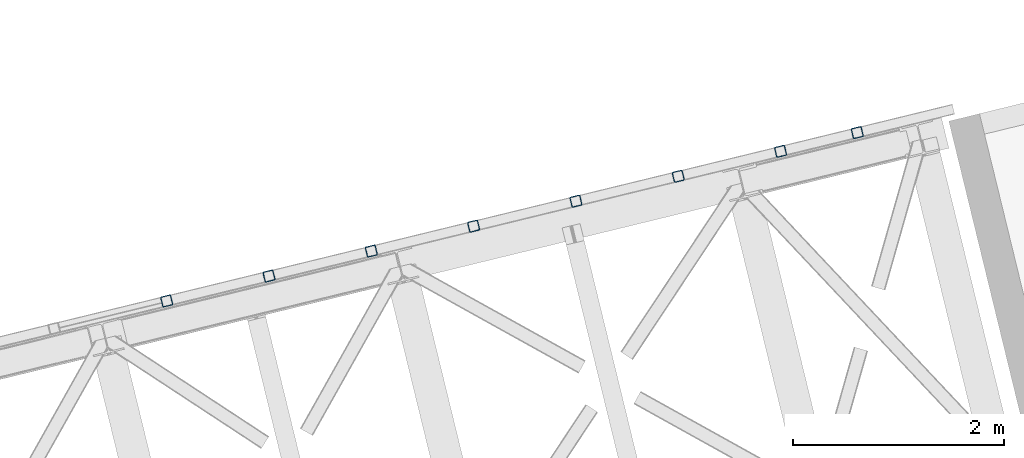
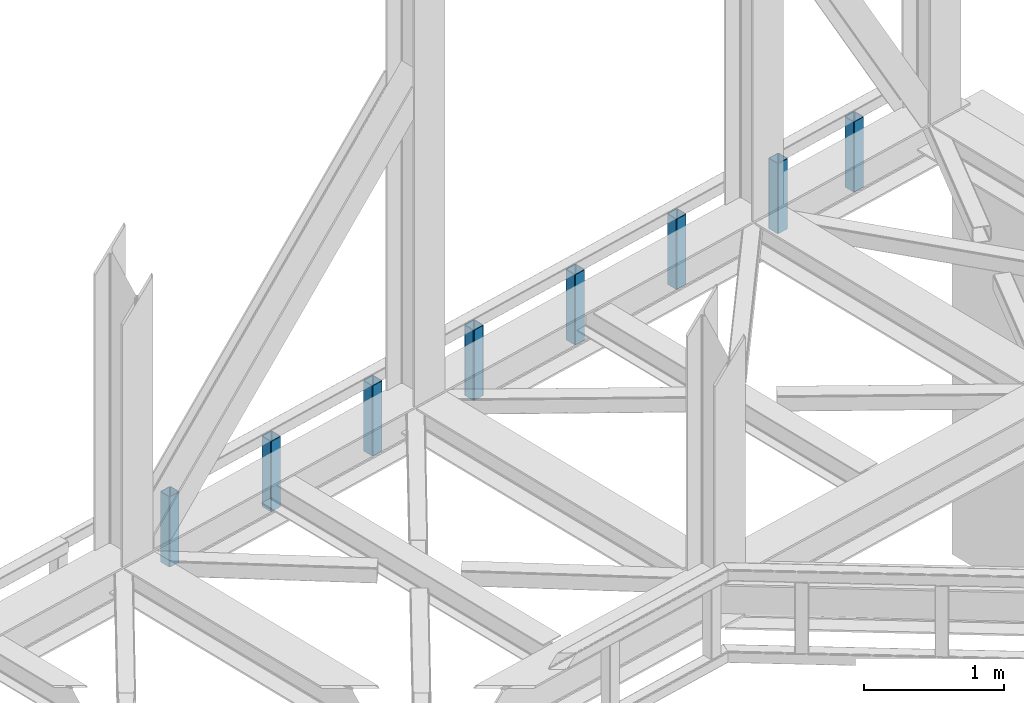
# One storey, part 14 of 92: 8 columns.
"""IFC4 building model written with IfcOpenShell, lengths in millimetres."""

from ifc_helpers import new_model, entity, si_unit, converted_unit, derived_unit, direction, frame, origin, place, context, subcontext, project, spatial, indexed_curve, outline, extrude, type_object, element, save


model = new_model("IFC4")

# Units and contexts
model_context = context("Model", 3, precision=0.01, world=origin(), true_north=direction((6.12303176911189e-17, 1.0)))
plan_context = context("Plan", 3, precision=0.01, world=origin(), true_north=direction((6.12303176911189e-17, 1.0)))
body_context = subcontext(model_context, "Body", "Model", "MODEL_VIEW")
ifc_project = project(units=[si_unit("LENGTHUNIT", "METRE", prefix="MILLI"), si_unit("AREAUNIT", "SQUARE_METRE"), si_unit("VOLUMEUNIT", "CUBIC_METRE"), converted_unit("PLANEANGLEUNIT", "DEGREE", entity("IfcRatioMeasure", 0.0174532925199433), si_unit("PLANEANGLEUNIT", "RADIAN"), dimensions=[0, 0, 0, 0, 0, 0, 0]), si_unit("MASSUNIT", "GRAM", prefix="KILO"), derived_unit("MASSDENSITYUNIT", [(si_unit("MASSUNIT", "GRAM", prefix="KILO"), 1), (si_unit("LENGTHUNIT", "METRE"), -3)]), derived_unit("MOMENTOFINERTIAUNIT", [(si_unit("LENGTHUNIT", "METRE"), 4)]), si_unit("TIMEUNIT", "SECOND"), si_unit("FREQUENCYUNIT", "HERTZ"), si_unit("THERMODYNAMICTEMPERATUREUNIT", "DEGREE_CELSIUS"), derived_unit("THERMALTRANSMITTANCEUNIT", [(si_unit("MASSUNIT", "GRAM", prefix="KILO"), 1), (si_unit("THERMODYNAMICTEMPERATUREUNIT", "KELVIN"), -1), (si_unit("TIMEUNIT", "SECOND"), -3)]), derived_unit("VOLUMETRICFLOWRATEUNIT", [(si_unit("LENGTHUNIT", "METRE"), 3), (si_unit("TIMEUNIT", "SECOND"), -1)]), derived_unit("MASSFLOWRATEUNIT", [(si_unit("MASSUNIT", "GRAM", prefix="KILO"), 1), (si_unit("TIMEUNIT", "SECOND"), -1)]), derived_unit("ROTATIONALFREQUENCYUNIT", [(si_unit("TIMEUNIT", "SECOND"), -1)]), si_unit("ELECTRICCURRENTUNIT", "AMPERE"), si_unit("ELECTRICVOLTAGEUNIT", "VOLT"), si_unit("POWERUNIT", "WATT"), si_unit("FORCEUNIT", "NEWTON", prefix="KILO"), si_unit("ILLUMINANCEUNIT", "LUX"), si_unit("LUMINOUSFLUXUNIT", "LUMEN"), si_unit("LUMINOUSINTENSITYUNIT", "CANDELA"), derived_unit("USERDEFINED", [(si_unit("MASSUNIT", "GRAM", prefix="KILO"), -1), (si_unit("LENGTHUNIT", "METRE"), -2), (si_unit("TIMEUNIT", "SECOND"), 3), (si_unit("LUMINOUSFLUXUNIT", "LUMEN"), 1)]), derived_unit("LINEARVELOCITYUNIT", [(si_unit("LENGTHUNIT", "METRE"), 1), (si_unit("TIMEUNIT", "SECOND"), -1)]), si_unit("PRESSUREUNIT", "PASCAL"), derived_unit("USERDEFINED", [(si_unit("LENGTHUNIT", "METRE"), -2), (si_unit("MASSUNIT", "GRAM", prefix="KILO"), 1), (si_unit("TIMEUNIT", "SECOND"), -2)]), derived_unit("LINEARFORCEUNIT", [(si_unit("MASSUNIT", "GRAM", prefix="KILO"), 1), (si_unit("LENGTHUNIT", "METRE"), 1), (si_unit("TIMEUNIT", "SECOND"), -2), (si_unit("LENGTHUNIT", "METRE"), -1)]), derived_unit("PLANARFORCEUNIT", [(si_unit("MASSUNIT", "GRAM", prefix="KILO"), 1), (si_unit("LENGTHUNIT", "METRE"), 1), (si_unit("TIMEUNIT", "SECOND"), -2), (si_unit("LENGTHUNIT", "METRE"), -2)])], contexts=[model_context, plan_context])

# Site, building, storey
site_placement = place(None, origin())
site = spatial("IfcSite", under=ifc_project, at=site_placement, CompositionType="ELEMENT")
building_placement = place(site_placement, origin())
building = spatial("IfcBuilding", under=site, at=building_placement, CompositionType="ELEMENT")
storey_placement = place(building_placement, frame((0.0, 0.0, 15900.0)))
storey = spatial("IfcBuildingStorey", under=building, at=storey_placement, Name="05", CompositionType="ELEMENT", Elevation=15900.0)

# Columns
column_type_1 = type_object("IfcColumnType", PredefinedType="COLUMN")
placement = place(storey_placement, origin())
element("IfcColumn", 1, at=placement, inside=storey, type_object=column_type_1, ObjectType="Steel Column", PredefinedType="COLUMN", context=body_context, shape_type="SweptSolid", body=[
    extrude(outline(indexed_curve([(29.476895115349, -56.8428769007929), (33.37870155567, -56.8428769007929), (36.9835006657009, -55.3497202197826), (39.7424944585237, -52.5907264269531), (41.2356511395288, -48.9859273169178), (56.8428769007947, 29.4768951153464), (56.8428769007946, 33.3787015556698), (55.3497202197922, 36.9835006657036), (52.5907264269645, 39.7424944585291), (48.9859273169309, 41.2356511395364), (-29.4768951153304, 56.8428769008034), (-33.3787015556703, 56.8428769008026), (-36.983500665692, 55.3497202197928), (-39.742494458524, 52.5907264269628), (-41.2356511395382, 48.985927316927), (-56.8428769008028, -29.4768951153331), (-56.8428769007949, -33.3787015556601), (-55.3497202197833, -36.9835006656934), (-52.5907264269653, -39.7424944585192), (-48.9859273169146, -41.2356511395297), (29.476895115349, -56.8428769007929)], self_intersect=False), holes=[indexed_curve([(-43.1065493048278, -37.3071763475883), (-46.7113484148565, -35.8140196665833), (-49.4703422076867, -33.0550258737518), (-50.963498888688, -29.4502267637233), (-50.9634988886983, -25.5484203234), (-37.3071763475896, 43.1065493048314), (-35.8140196665759, 46.7113484148674), (-33.0550258737591, 49.4703422076902), (-29.4502267637216, 50.9634988887021), (-25.5484203234027, 50.9634988887079), (43.1065493048406, 37.3071763475967), (46.7113484148732, 35.8140196665899), (49.4703422077042, 33.0550258737675), (50.9634988887097, 29.4502267637276), (50.9634988887155, 25.5484203234063), (37.3071763476012, -43.1065493048272), (35.8140196665999, -46.7113484148594), (33.055025873766, -49.4703422076933), (29.4502267637393, -50.963498888696), (25.5484203234126, -50.9634988886982), (-43.1065493048278, -37.3071763475883)], self_intersect=False)]), frame((-2530.87, 20381.28, 3168.0), z_axis=(0.0, 0.0, 1.0), x_axis=(0.906681479027445, 0.4218159498983, 0.0)), (0.0, 0.0, 1.0), 612.000000000008),
])
column_type_2 = type_object("IfcColumnType", PredefinedType="COLUMN")
element("IfcColumn", 2, at=placement, inside=storey, type_object=column_type_2, ObjectType="Steel Column", PredefinedType="COLUMN", context=body_context, shape_type="SweptSolid", body=[
    extrude(outline(indexed_curve([(29.476895115345, -56.8428769007958), (33.378701555666, -56.8428769007958), (36.9835006656971, -55.3497202197856), (39.7424944585291, -52.5907264269556), (41.2356511395342, -48.9859273169203), (56.8428769007987, 29.4768951153397), (56.8428769007984, 33.3787015556633), (55.3497202197884, 36.9835006657005), (52.590726426961, 39.742494458526), (48.9859273169274, 41.2356511395333), (-29.4768951153439, 56.8428769008001), (-33.3787015556647, 56.8428769008), (-36.9835006657036, 55.3497202197934), (-39.7424944585184, 52.5907264269601), (-41.2356511395328, 48.9859273169245), (-56.8428769007992, -29.4768951153395), (-56.8428769007892, -33.3787015556628), (-55.3497202197947, -36.9835006656929), (-52.5907264269596, -39.7424944585218), (-48.9859273169261, -41.2356511395291), (29.476895115345, -56.8428769007958)], self_intersect=False), holes=[indexed_curve([(-43.1065493048226, -37.3071763475907), (-46.7113484148589, -35.8140196665822), (-49.4703422076883, -33.0550258737558), (-50.9634988886878, -29.4502267637235), (-50.9634988886929, -25.5484203234025), (-37.3071763475806, 43.1065493048272), (-35.814019666583, 46.7113484148611), (-33.0550258737619, 49.470342207701), (-29.4502267637245, 50.9634988887035), (-25.548420323398, 50.9634988887057), (43.1065493048361, 37.307176347594), (46.711348414869, 35.8140196665871), (49.4703422076887, 33.0550258737604), (50.9634988887073, 29.4502267637335), (50.9634988887034, 25.5484203234071), (37.3071763475911, -43.1065493048225), (35.8140196665901, -46.7113484148644), (33.0550258737647, -49.4703422076879), (29.450226763735, -50.9634988886988), (25.5484203234099, -50.9634988886969), (-43.1065493048226, -37.3071763475907)], self_intersect=False)]), frame((-1802.21, 20558.9, 3168.0), z_axis=(0.0, 0.0, 1.0), x_axis=(0.906681479027445, 0.4218159498983, 0.0)), (0.0, 0.0, 1.0), 612.000000000008),
])
column_type_3 = type_object("IfcColumnType", PredefinedType="COLUMN")
element("IfcColumn", 3, at=placement, inside=storey, type_object=column_type_3, ObjectType="Steel Column", PredefinedType="COLUMN", context=body_context, shape_type="SweptSolid", body=[
    extrude(outline(indexed_curve([(29.4768951153362, -56.8428769008013), (33.3787015556572, -56.8428769008013), (36.9835006656959, -55.3497202197946), (39.7424944585279, -52.5907264269646), (41.2356511395251, -48.9859273169257), (56.8428769007897, 29.4768951153344), (56.8428769007988, 33.3787015556583), (55.3497202197867, 36.9835006656918), (52.5907264269517, 39.7424944585208), (48.9859273169181, 41.235651139528), (-29.4768951153359, 56.8428769007916), (-33.3787015556661, 56.8428769007911), (-36.9835006656956, 55.3497202197849), (-39.7424944585369, 52.5907264269544), (-41.2356511395322, 48.9859273169194), (-56.8428769007986, -29.4768951153446), (-56.8428769008077, -33.3787015556685), (-55.3497202197869, -36.9835006657012), (-52.5907264269611, -39.7424944585307), (-48.9859273169183, -41.2356511395375), (29.4768951153362, -56.8428769008013)], self_intersect=False), holes=[indexed_curve([(-43.1065493048338, -37.3071763475999), (-46.7113484148666, -35.8140196665834), (-49.4703422076999, -33.0550258737647), (-50.9634988887023, -29.450226763731), (-50.9634988887121, -25.5484203234079), (-37.3071763476053, 43.1065493048196), (-35.8140196665908, 46.7113484148456), (-33.0550258737653, 49.4703422076834), (-29.4502267637372, 50.9634988886903), (-25.5484203234091, 50.9634988886966), (43.106549304825, 37.3071763475849), (46.7113484148594, 35.814019666582), (49.4703422076904, 33.0550258737596), (50.9634988887041, 29.4502267637206), (50.9634988887017, 25.5484203233984), (37.3071763475891, -43.1065493048312), (35.8140196665818, -46.7113484148701), (33.055025873744, -49.4703422077022), (29.4502267637237, -50.9634988887079), (25.5484203234066, -50.9634988887097), (-43.1065493048338, -37.3071763475999)], self_intersect=False)]), frame((-3502.43, 20144.45, 3168.0), z_axis=(0.0, 0.0, 1.0), x_axis=(0.906681479027445, 0.4218159498983, 0.0)), (0.0, 0.0, 1.0), 612.000000000008),
])
column_type_4 = type_object("IfcColumnType", PredefinedType="COLUMN")
element("IfcColumn", 4, at=placement, inside=storey, type_object=column_type_4, ObjectType="Steel Column", PredefinedType="COLUMN", context=body_context, shape_type="SweptSolid", body=[
    extrude(outline(indexed_curve([(29.4768951152886, -56.8428769008306), (33.3787015556115, -56.8428769008306), (36.9835006656346, -55.3497202198244), (39.7424944584773, -52.5907264270008), (41.235651139486, -48.9859273169671), (56.8428769008309, 29.4768951152814), (56.8428769008347, 33.3787015556048), (55.3497202198189, 36.9835006656432), (52.5907264270037, 39.7424944584719), (48.9859273169698, 41.2356511394788), (-29.4768951152837, 56.8428769008284), (-33.3787015556066, 56.8428769008284), (-36.9835006656376, 55.3497202198258), (-39.7424944584719, 52.5907264269983), (-41.2356511394903, 48.9859273169643), (-56.8428769008356, -29.476895115284), (-56.8428769008298, -33.3787015556071), (-55.3497202198218, -36.9835006656418), (-52.5907264269988, -39.7424944584741), (-48.9859273169667, -41.235651139485), (29.4768951152886, -56.8428769008306)], self_intersect=False), holes=[indexed_curve([(-43.1065493048588, -37.3071763475528), (-46.7113484148957, -35.8140196665444), (-49.4703422077166, -33.0550258737036), (-50.9634988887208, -29.4502267636802), (-50.9634988887253, -25.5484203233529), (-37.3071763475476, 43.1065493048648), (-35.8140196665321, 46.7113484148953), (-33.0550258737185, 49.4703422077229), (-29.4502267636721, 50.9634988887278), (-25.5484203233453, 50.963498888726), (43.1065493048588, 37.3071763475528), (46.7113484149019, 35.8140196665463), (49.4703422077228, 33.0550258737055), (50.9634988887283, 29.4502267636719), (50.9634988887302, 25.5484203233506), (37.3071763475569, -43.1065493048691), (35.8140196665473, -46.7113484149024), (33.0550258737157, -49.4703422077264), (29.4502267636678, -50.9634988887306), (25.5484203233507, -50.9634988887285), (-43.1065493048588, -37.3071763475528)], self_intersect=False)]), frame((-4473.98, 19907.62, 3168.0), z_axis=(0.0, 0.0, 1.0), x_axis=(0.90668147902702, 0.421815949899212, 0.0)), (0.0, 0.0, 1.0), 612.000000000008),
])
column_type_5 = type_object("IfcColumnType", PredefinedType="COLUMN")
element("IfcColumn", 5, at=placement, inside=storey, type_object=column_type_5, ObjectType="Steel Column", PredefinedType="COLUMN", context=body_context, shape_type="SweptSolid", body=[
    extrude(outline(indexed_curve([(29.4768951153449, -56.8428769008005), (33.3787015556659, -56.8428769008005), (36.9835006656972, -55.3497202197904), (39.7424944585201, -52.5907264269609), (41.2356511395246, -48.9859273169254), (56.8428769007915, 29.4768951153383), (56.8428769007905, 33.3787015556622), (55.3497202197885, 36.9835006656957), (52.5907264269614, 39.7424944585211), (48.9859273169273, 41.2356511395286), (-29.4768951153341, 56.8428769007955), (-33.3787015556569, 56.8428769007916), (-36.9835006656961, 55.3497202197851), (-39.7424944585277, 52.5907264269549), (-41.2356511395419, 48.9859273169191), (-56.8428769008069, -29.4768951153407), (-56.842876900799, -33.3787015556678), (-55.3497202197864, -36.9835006657015), (-52.5907264269514, -39.7424944585305), (-48.9859273169183, -41.2356511395375), (29.4768951153449, -56.8428769008005)], self_intersect=False), holes=[indexed_curve([(-43.1065493048309, -37.3071763475964), (-46.7113484148583, -35.8140196665873), (-49.4703422076876, -33.0550258737562), (-50.9634988886951, -29.4502267637296), (-50.9634988886922, -25.5484203234076), (-37.3071763475802, 43.1065493048222), (-35.8140196665777, 46.7113484148634), (-33.0550258737595, 49.4703422076855), (-29.4502267637242, 50.9634988886938), (-25.5484203234063, 50.9634988887), (43.106549304837, 37.3071763475888), (46.7113484148719, 35.8140196665857), (49.470342207695, 33.055025873767), (50.963498888706, 29.4502267637198), (50.963498888704, 25.5484203234021), (37.3071763475998, -43.1065493048313), (35.8140196665912, -46.7113484148601), (33.0550258737647, -49.4703422076975), (29.4502267637362, -50.9634988887041), (25.5484203234094, -50.9634988887062), (-43.1065493048309, -37.3071763475964)], self_intersect=False)]), frame((-5445.53, 19670.8, 3168.0), z_axis=(0.0, 0.0, 1.0), x_axis=(0.906681479027445, 0.4218159498983, 0.0)), (0.0, 0.0, 1.0), 612.000000000008),
])
column_type_6 = type_object("IfcColumnType", PredefinedType="COLUMN")
element("IfcColumn", 6, at=placement, inside=storey, type_object=column_type_6, ObjectType="Steel Column", PredefinedType="COLUMN", context=body_context, shape_type="SweptSolid", body=[
    extrude(outline(indexed_curve([(29.4768951153477, -56.8428769007971), (33.3787015556687, -56.8428769007971), (36.9835006656913, -55.3497202197853), (39.7424944585219, -52.590726426957), (41.2356511395362, -48.9859273169237), (56.8428769008021, 29.4768951153406), (56.8428769007933, 33.3787015556657), (55.3497202197817, 36.9835006656989), (52.5907264269641, 39.742494458527), (48.9859273169301, 41.235651139532), (-29.4768951153419, 56.8428769007991), (-33.3787015556716, 56.8428769007984), (-36.9835006656933, 55.3497202197886), (-39.7424944585249, 52.5907264269584), (-41.2356511395304, 48.9859273169233), (-56.8428769007954, -29.4768951153389), (-56.8428769007953, -33.3787015556623), (-55.3497202197846, -36.9835006656975), (-52.5907264269671, -39.7424944585232), (-48.9859273169233, -41.2356511395304), (29.4768951153477, -56.8428769007971)], self_intersect=False), holes=[indexed_curve([(-43.1065493048213, -37.3071763475961), (-46.7113484148504, -35.8140196665933), (-49.4703422076942, -33.0550258737627), (-50.9634988886903, -29.450226763727), (-50.9634988887001, -25.5484203234039), (-37.3071763475929, 43.1065493048257), (-35.8140196665786, 46.7113484148615), (-33.0550258737509, 49.4703422076887), (-29.4502267637137, 50.9634988886985), (-25.5484203233966, 50.9634988887003), (43.10654930483, 37.3071763475944), (46.7113484148659, 35.8140196665933), (49.4703422076992, 33.0550258737555), (50.9634988887157, 29.4502267637224), (50.9634988887128, 25.5484203234004), (37.3071763476077, -43.106549304835), (35.8140196666, -46.7113484148618), (33.0550258737664, -49.4703422076911), (29.4502267637284, -50.9634988887029), (25.5484203234025, -50.9634988887006), (-43.1065493048213, -37.3071763475961)], self_intersect=False)]), frame((-6417.08, 19433.97, 3168.0), z_axis=(0.0, 0.0, 1.0), x_axis=(0.906681479027445, 0.4218159498983, 0.0)), (0.0, 0.0, 1.0), 612.000000000008),
])
column_type_7 = type_object("IfcColumnType", PredefinedType="COLUMN")
element("IfcColumn", 7, at=placement, inside=storey, type_object=column_type_7, ObjectType="Steel Column", PredefinedType="COLUMN", context=body_context, shape_type="SweptSolid", body=[
    extrude(outline(indexed_curve([(29.4768951153389, -56.8428769007929), (33.3787015556599, -56.8428769007929), (36.9835006656981, -55.349720219786), (39.7424944585306, -52.5907264269562), (41.2356511395264, -48.9859273169191), (56.8428769007933, 29.4768951153447), (56.842876900801, 33.3787015556669), (55.3497202197894, 36.9835006657001), (52.5907264269544, 39.7424944585291), (48.9859273169203, 41.2356511395366), (-29.4768951153332, 56.8428769007999), (-33.3787015556552, 56.8428769007979), (-36.9835006657021, 55.3497202197927), (-39.7424944585171, 52.5907264269595), (-41.2356511395227, 48.9859273169245), (-56.8428769007886, -29.4768951153397), (-56.8428769007876, -33.3787015556612), (-55.3497202197934, -36.9835006656934), (-52.5907264269497, -39.7424944585241), (-48.9859273169156, -41.2356511395292), (29.4768951153389, -56.8428769007929)], self_intersect=False), holes=[indexed_curve([(-43.1065493048301, -37.307176347592), (-46.7113484148643, -35.8140196665797), (-49.4703422076903, -33.0550258737621), (-50.963498888703, -29.4502267637235), (-50.9634988887002, -25.5484203234015), (-37.3071763475899, 43.1065493048243), (-35.8140196665854, 46.7113484148622), (-33.055025873752, 49.470342207694), (-29.4502267637303, 50.9634988887038), (-25.5484203234055, 50.9634988887044), (43.10654930483, 37.3071763475969), (46.7113484148641, 35.8140196665894), (49.4703422077019, 33.0550258737614), (50.9634988887068, 29.4502267637266), (50.9634988887049, 25.5484203234065), (37.3071763475937, -43.1065493048213), (35.8140196665853, -46.7113484148574), (33.0550258737663, -49.4703422076863), (29.4502267637273, -50.9634988887), (25.5484203234112, -50.9634988886999), (-43.1065493048301, -37.307176347592)], self_intersect=False)]), frame((-7388.63, 19197.15, 3168.0), z_axis=(0.0, 0.0, 1.0), x_axis=(0.906681479027445, 0.4218159498983, 0.0)), (0.0, 0.0, 1.0), 612.000000000008),
])
column_type_8 = type_object("IfcColumnType", PredefinedType="COLUMN")
element("IfcColumn", 8, at=placement, inside=storey, type_object=column_type_8, ObjectType="Steel Column", PredefinedType="COLUMN", context=body_context, shape_type="SweptSolid", body=[
    extrude(outline(indexed_curve([(29.4768951153439, -56.8428769008001), (33.3787015556649, -56.8428769008001), (36.9835006656875, -55.3497202197883), (39.7424944585269, -52.5907264269617), (41.2356511395324, -48.9859273169267), (56.8428769007983, 29.4768951153376), (56.8428769007982, 33.378701555661), (55.3497202197779, 36.9835006656959), (52.5907264269603, 39.7424944585239), (48.9859273169263, 41.235651139529), (-29.476895115337, 56.8428769007944), (-33.3787015556667, 56.8428769007937), (-36.9835006657059, 55.3497202197873), (-39.7424944585286, 52.5907264269553), (-41.2356511395342, 48.9859273169203), (-56.8428769007991, -29.4768951153419), (-56.8428769007991, -33.3787015556654), (-55.3497202197972, -36.9835006656989), (-52.5907264269621, -39.7424944585279), (-48.9859273169194, -41.2356511395346), (29.4768951153439, -56.8428769008001)], self_intersect=False), holes=[indexed_curve([(-43.1065493048251, -37.3071763475992), (-46.711348414862, -35.8140196665927), (-49.4703422076902, -33.0550258737645), (-50.9634988886941, -29.4502267637301), (-50.9634988887039, -25.5484203234069), (-37.3071763475967, 43.1065493048227), (-35.8140196665843, 46.7113484148569), (-33.0550258737627, 49.4703422076942), (-29.4502267637254, 50.9634988886991), (-25.5484203234004, 50.9634988886973), (43.1065493048184, 37.3071763475951), (46.7113484148689, 35.8140196665895), (49.4703422076932, 33.0550258737631), (50.9634988887039, 29.4502267637255), (50.9634988887021, 25.548420323403), (37.30717634759, -43.1065493048268), (35.8140196665886, -46.7113484148709), (33.0550258737627, -49.4703422076942), (29.4502267637167, -50.9634988887023), (25.5484203233987, -50.9634988887036), (-43.1065493048251, -37.3071763475992)], self_intersect=False)]), frame((-8360.19, 18960.32, 3168.0), z_axis=(0.0, 0.0, 1.0), x_axis=(0.906681479027445, 0.4218159498983, 0.0)), (0.0, 0.0, 1.0), 612.000000000008),
])

save(model, "model.ifc")
